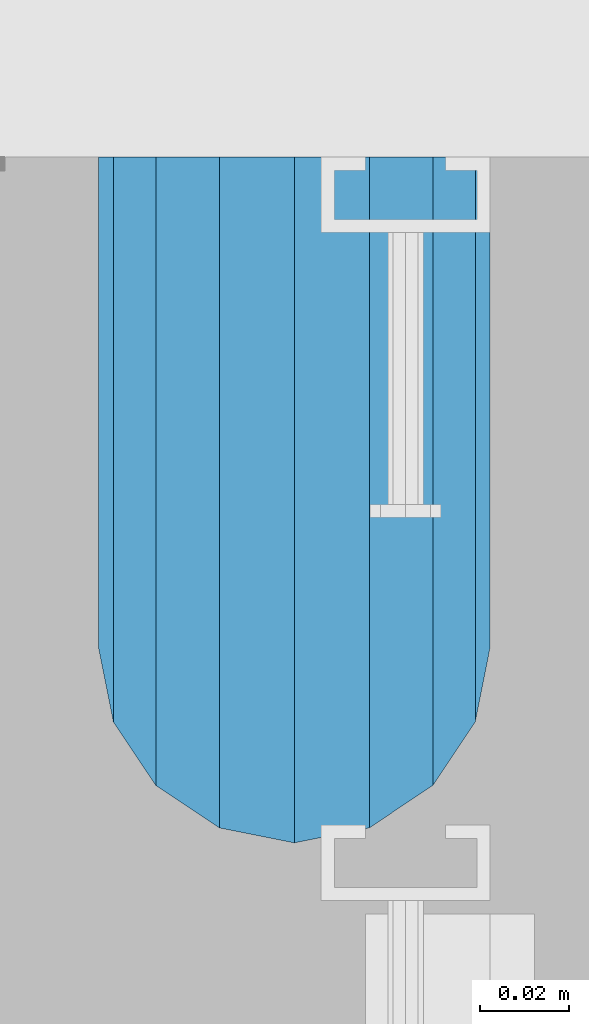
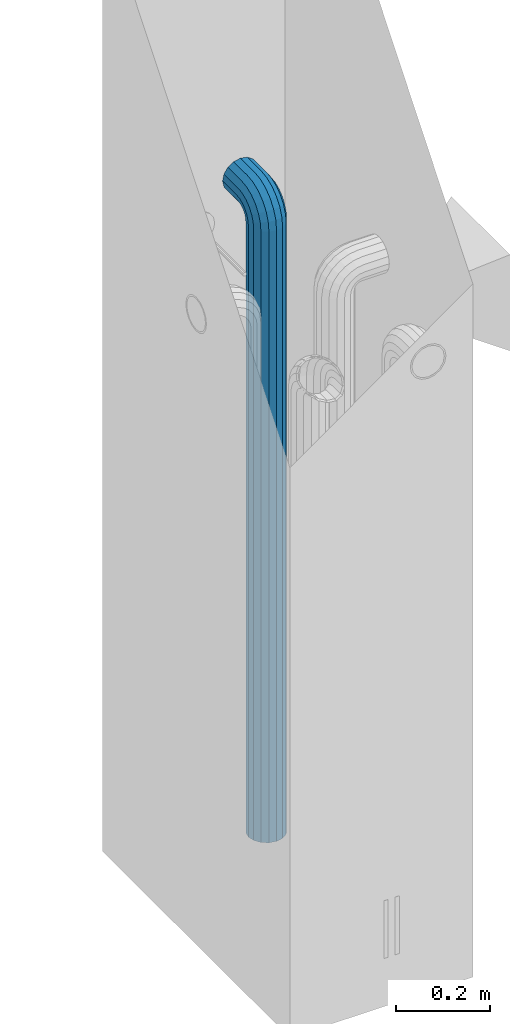
# One storey, part 5 of 41: 1 beam, 2 elements without a shape of their own.
"""IFC2X3 building model written with IfcOpenShell, lengths in millimetres."""

from ifc_helpers import new_model, si_unit, frame, origin_with_axes, place, context, subcontext, project, spatial, faceted_brep, material, type_object, element, aggregate, save


model = new_model("IFC2X3")

# Units and contexts
model_context = context("Model", 3, precision=1e-05, world=origin_with_axes())
body_context = subcontext(model_context, "Body", "Model", "MODEL_VIEW")
ifc_project = project(units=[si_unit("LENGTHUNIT", "METRE", prefix="MILLI"), si_unit("AREAUNIT", "SQUARE_METRE"), si_unit("VOLUMEUNIT", "CUBIC_METRE"), si_unit("MASSUNIT", "GRAM", prefix="KILO"), si_unit("TIMEUNIT", "SECOND"), si_unit("PLANEANGLEUNIT", "RADIAN"), si_unit("SOLIDANGLEUNIT", "STERADIAN"), si_unit("THERMODYNAMICTEMPERATUREUNIT", "DEGREE_CELSIUS"), si_unit("LUMINOUSINTENSITYUNIT", "LUMEN")], contexts=[model_context])

# Site, building, storey
site_placement = place(None, frame((-177556.685383467, -198018.589999756, 1290.0), z_axis=(0.0, 0.0, 1.0), x_axis=(0.788225611989142, -0.615386370180835, 0.0)))
site = spatial("IfcSite", under=ifc_project, at=site_placement, CompositionType="ELEMENT")
building_placement = place(site_placement, origin_with_axes())
building = spatial("IfcBuilding", under=site, at=building_placement, Name="Undefined", CompositionType="ELEMENT")
storey_placement = place(building_placement, origin_with_axes())
storey = spatial("IfcBuildingStorey", under=building, at=storey_placement, Name="Undefined", CompositionType="ELEMENT", Elevation=0.0)

# Assemblies, beam
assembly_1_placement = place(storey_placement, origin_with_axes())
assembly_1 = element("IfcElementAssembly", 1, at=assembly_1_placement, inside=storey, AssemblyPlace="NOTDEFINED", PredefinedType="REINFORCEMENT_UNIT")
assembly_2_placement = place(assembly_1_placement, origin_with_axes())
assembly_2 = element("IfcElementAssembly", 2, at=assembly_2_placement, AssemblyPlace="NOTDEFINED", PredefinedType="RIGID_FRAME")
aggregate(assembly_1, [assembly_2])
ifc_material = material(Name="STEEL/NEG_BETON")
beam_type = type_object("IfcBeamType", PredefinedType="NOTDEFINED")
beam_placement = place(assembly_2_placement, frame((18008.9695688979, 265648.643267305, -1290.0), z_axis=(0.615386370178831, -0.788225611990706, 0.0), x_axis=(0.0, 0.0, 1.0)))
beam = element("IfcBeam", 3, at=beam_placement, type_object=beam_type, material=ifc_material, context=body_context, shape_type="Brep", body=[
    faceted_brep([(0.0, -43.999999753345, 2.88331648334861e-07), (0.0, -40.6506991838105, -16.8380707357428), (1590.0, -40.6506991838105, -16.8380707357428), (1589.99999999999, -43.999999753345, 2.88331648334861e-07), (0.0, -31.1126981254783, -31.1126980838017), (1590.0, -31.1126981254783, -31.1126980838017), (0.0, -16.8380707773322, -40.6506991419883), (1590.0, -16.8380707773322, -40.6506991419883), (0.0, 2.46742274612188e-07, -43.9999997114064), (1590.0, 2.46742274612188e-07, -43.9999997114064), (0.0, 16.8380712707876, -40.6506991418137), (1590.0, 16.8380712707876, -40.6506991418137), (0.0, 31.1126986189047, -31.1126980834524), (1590.0, 31.1126986189047, -31.1126980834524), (0.0, 40.6506996771204, -16.8380707352771), (1590.0, 40.6506996771204, -16.8380707352771), (0.0, 44.0000002465677, 2.88768205791712e-07), (1590.0, 44.0000002465677, 2.88768205791712e-07), (0.0, 40.6506996770622, 16.8380713128427), (1590.0, 40.6506996770622, 16.8380713128427), (0.0, 31.1126986187301, 31.1126986609306), (1590.0, 31.1126986187301, 31.1126986609306), (0.0, 16.8380712705839, 40.6506997191464), (1590.0, 16.8380712705839, 40.6506997191464), (0.0, 2.46509443968534e-07, 44.0000002885354), (1590.0, 2.46509443968534e-07, 44.0000002885354), (0.0, -16.8380707775359, 40.6506997189426), (1590.0, -16.8380707775359, 40.6506997189426), (0.0, -31.1126981256821, 31.1126986605814), (1590.0, -31.1126981256821, 31.1126986605814), (0.0, -40.6506991838978, 16.838071312377), (1590.0, -40.6506991838978, 16.838071312377), (4.47878846898675e-07, -40.0000000634464, 0.0), (4.47878846898675e-07, -36.9551813638827, 15.3073372946019), (1590.0, -36.9551810538396, 15.3073375829845), (1589.99999999999, -39.999999753345, 2.88360752165318e-07), (4.47937054559588e-07, -28.2842713108694, 28.284271247463), (1590.0, -28.2842710008845, 28.2842715359002), (4.4800981413573e-07, -15.3073373580119, 36.9551813004509), (1590.0, -15.3073370480561, 36.9551815889135), (4.48068021796644e-07, -6.34463503956795e-08, 40.0), (1590.0, 2.46538547798991e-07, 40.0000002885645), (4.48140781372786e-07, 15.3073372311774, 36.9551813004509), (1590.0, 15.3073375411332, 36.9551815890882), (4.48213540948927e-07, 28.2842711840058, 28.284271247463), (1590.0, 28.2842714939907, 28.2842715361621), (4.48271748609841e-07, 36.95518123699, 15.3073372946019), (1590.0, 36.9551815469749, 15.3073375833046), (4.48286300525069e-07, 39.9999999365536, 0.0), (1590.0, 40.0000002465677, 2.88768205791712e-07), (4.48271748609841e-07, 36.95518123699, -15.3073372946019), (1590.0, 36.9551815470913, -15.3073370058555), (4.48213540948927e-07, 28.2842711840058, -28.284271247463), (1590.0, 28.2842714941071, -28.2842709587712), (4.48140781372786e-07, 15.3073372311774, -36.9551813004509), (1590.0, 15.3073375413369, -36.9551810117846), (4.48068021796644e-07, -6.34463503956795e-08, -40.0), (1590.0, 2.46742274612188e-07, -39.9999997114064), (4.4800981413573e-07, -15.3073373580119, -36.9551813004509), (1590.0, -15.3073370479106, -36.9551810119592), (4.47937054559588e-07, -28.2842713108694, -28.284271247463), (1590.0, -28.284271000739, -28.2842709590332), (4.47878846898675e-07, -36.9551813638827, -15.3073372946019), (1590.0, -36.9551810537523, -15.3073370062048), (1602.94095225512, -43.9999997526465, -1.70370839745738), (1607.29896571893, -40.6506991831702, 14.560619269585), (1610.99351113838, -31.1126981249254, 28.3488504858688), (1613.46212746447, -16.8380707768374, 37.5618520393036), (1614.32899023963, 2.47237039729953e-07, 40.7970279594592), (1613.46212746447, 16.8380712712533, 37.5618520394491), (1610.99351113838, 31.1126986194577, 28.3488504861598), (1607.29896571893, 40.6506996777607, 14.5606192699925), (1602.94095225512, 44.0000002472952, -1.70370839699171), (1598.5829387913, 40.650699677848, -17.9680360640341), (1594.88839337186, 31.1126986196032, -31.7562672803178), (1592.41977704577, 16.8380712714861, -40.9692688337527), (1591.55291427061, 2.4744076654315e-07, -44.2044447539374), (1592.41977704577, -16.8380707766337, -40.9692688339564), (1594.88839337186, -31.1126981247508, -31.7562672806089), (1598.5829387913, -40.6506991830829, -17.9680360644415), (1613.29371405922, 2.47237039729953e-07, 36.9333246542956), (1612.50565699089, -15.3073370473576, 33.992255635967), (1610.26146033081, -28.284271000186, 25.6167996783042), (1606.90278267677, -36.9551810531411, 13.0820440271636), (1602.94095225512, -39.9999997526465, -1.70370839745738), (1598.97912183347, -36.9551810530538, -16.4894608219911), (1595.62044417943, -28.2842710000114, -29.0242164730153), (1593.37624751934, -15.3073370471539, -37.3996724305616), (1592.58819045102, 2.47411662712693e-07, -40.3407414487447), (1593.37624751934, 15.3073375420063, -37.3996724304452), (1595.62044417943, 28.2842714948347, -29.0242164727533), (1598.97912183347, 36.9551815478189, -16.4894608215836), (1602.94095225512, 40.0000002472952, -1.70370839699171), (1606.90278267677, 36.9551815477316, 13.082044027542), (1610.26146033081, 28.2842714946892, 25.6167996785662), (1612.50565699089, 15.3073375418317, 33.9922556361125), (1630.55634918609, -31.1126981248963, 20.2456576479599), (1635.32534971524, -16.8380707767792, 28.5058088658843), (1623.41903551202, -40.6506991831702, 7.88346773487865), (1614.99999999999, -43.9999997526465, -6.69872952270089), (1606.58096448796, -40.6506991830829, -21.2809267801931), (1599.44365081389, -31.1126981247799, -33.6431166932161), (1594.67465028474, -16.8380707766337, -41.9032679109368), (1592.99999999999, 2.4744076654315e-07, -44.8038472889457), (1594.67465028474, 16.8380712714861, -41.9032679107622), (1599.44365081389, 31.1126986195741, -33.6431166929251), (1606.58096448796, 40.650699677848, -21.2809267798148), (1614.99999999999, 44.0000002472952, -6.69872952226433), (1623.41903551202, 40.6506996777898, 7.88346773531521), (1630.55634918609, 31.1126986194577, 20.24565764828), (1635.32534971524, 16.8380712713115, 28.5058088660007), (1636.99999999999, 2.4726614356041e-07, 31.4063882440387), (1633.47759065022, 15.3073375418608, 25.3053962852573), (1634.99999999999, 2.4726614356041e-07, 27.9422866288805), (1629.14213562372, 28.2842714947183, 17.7961679055006), (1622.65366864729, 36.9551815477607, 6.55781343916897), (1614.99999999999, 40.0000002473244, -6.69872952226433), (1607.34633135269, 36.9551815477898, -19.9552724836976), (1600.85786437626, 28.2842714948347, -31.1936269501166), (1596.52240934976, 15.3073375420354, -38.7028553300188), (1594.99999999999, 2.47411662712693e-07, -41.3397456738458), (1596.52240934976, -15.3073370471539, -38.7028553301352), (1600.85786437626, -28.2842710000696, -31.1936269504367), (1607.34633135269, -36.9551810530538, -19.9552724840469), (1614.99999999999, -39.9999997526465, -6.69872952267178), (1622.65366864729, -36.955181053112, 6.55781343879062), (1629.14213562372, -28.2842710001278, 17.7961679052387), (1633.47759065022, -15.3073370472994, 25.3053962851118), (1647.35533905931, -31.1126981248963, 7.35533934747218), (1654.09972428659, -16.8380707767792, 14.0997245748003), (1637.26165326253, -40.6506991831411, -2.73834644936142), (1625.35533905931, -43.9999997526174, -14.644660652586), (1613.4490248561, -40.650699183112, -26.5509748557815), (1603.35533905931, -31.1126981247508, -36.6446606524696), (1596.61095383203, -16.8380707766046, -43.3890458796814), (1594.24264068711, 2.4744076654315e-07, -45.7573590245447), (1596.61095383203, 16.8380712714861, -43.3890458795358), (1603.35533905931, 31.1126986196032, -36.6446606521786), (1613.4490248561, 40.6506996778771, -26.550974855345), (1625.35533905931, 44.0000002473244, -14.6446606521204), (1637.26165326253, 40.6506996778189, -2.73834644892486), (1647.35533905931, 31.1126986194868, 7.35533934779232), (1654.09972428659, 16.8380712713406, 14.0997245750041), (1656.46803743151, 2.47295247390866e-07, 16.4680377198383), (1651.48659835683, 15.3073375418899, 11.4865986451914), (1653.63961030677, 2.47295247390866e-07, 13.6396105950989), (1645.35533905931, 28.2842714947474, 5.35533934776322), (1636.17926106223, 36.9551815477607, -3.82073864925769), (1625.35533905931, 40.0000002473244, -14.6446606521204), (1614.53141705639, 36.9551815478189, -25.4685826550995), (1605.35533905931, 28.2842714948638, -34.6446606522077), (1599.22407976179, 15.3073375420063, -40.7759199497814), (1597.07106781185, 2.4744076654315e-07, -42.9289318997762), (1599.22407976179, -15.3073370471539, -40.7759199499269), (1605.35533905931, -28.2842710000405, -34.6446606524696), (1614.53141705639, -36.9551810530247, -25.4685826554487), (1625.35533905931, -39.9999997526174, -14.644660652586), (1636.17926106223, -36.9551810530829, -3.82073864963604), (1645.35533905931, -28.2842710001278, 5.35533934750129), (1651.48659835683, -15.3073370472994, 11.486598645075), (1660.24565735981, -31.1126981248381, -9.44365052573266), (1668.50580857761, -16.838070776721, -4.67464999653748), (1647.88346744676, -40.6506991830829, -16.5809641998203), (1633.3012701892, -43.9999997525592, -24.9999997119012), (1618.71907293164, -40.6506991830538, -33.4190352238948), (1606.35688301859, -31.1126981247508, -40.5563488978951), (1598.09673180079, -16.8380707766337, -45.3253494270029), (1595.19615242269, 2.47469870373607e-07, -46.9999997116392), (1598.09673180079, 16.8380712714861, -45.3253494267992), (1606.35688301859, 31.1126986196032, -40.556348897604), (1618.71907293164, 40.6506996778771, -33.4190352235164), (1633.3012701892, 44.0000002473535, -24.9999997114355), (1647.88346744676, 40.650699677848, -16.580964199442), (1660.24565735981, 31.1126986195159, -9.44365052544163), (1668.50580857761, 16.8380712713988, -4.67464999633376), (1671.40638795571, 2.47324351221323e-07, -2.99999971169746), (1665.30539599684, 15.307337541919, -6.52240906140651), (1667.94228634057, 2.47324351221323e-07, -4.99999971172656), (1657.79616761703, 28.2842714948056, -10.8578640878259), (1646.55781315062, 36.9551815477898, -17.3463310641819), (1633.3012701892, 40.0000002473826, -24.9999997114355), (1620.04472722778, 36.955181547848, -32.6536683587765), (1608.80637276137, 28.2842714948638, -39.1421353352489), (1601.29714438156, 15.3073375420063, -43.4775903618138), (1598.66025403783, 2.47469870373607e-07, -44.9999997116392), (1601.29714438156, -15.3073370471539, -43.4775903619302), (1608.80637276137, -28.2842710000114, -39.1421353355108), (1620.04472722778, -36.9551810530247, -32.6536683591548), (1633.3012701892, -39.9999997525883, -24.9999997119012), (1646.55781315062, -36.9551810530538, -17.3463310645602), (1657.79616761703, -28.2842710000987, -10.8578640880878), (1665.30539599684, -15.3073370472412, -6.52240906155203), (1668.34885019768, -31.1126981247799, -29.0064885734755), (1677.56185175105, -16.8380707766628, -26.5378722472815), (1654.56061898146, -40.6506991830538, -32.7010339929548), (1638.29629131443, -43.9999997525592, -37.0590474567725), (1622.0319636474, -40.6506991830538, -41.4170609205903), (1608.24373243118, -31.1126981247508, -45.111606339924), (1599.03073087781, -16.8380707766046, -47.5802226659725), (1595.79555495772, 2.47469870373607e-07, -48.447085441032), (1599.03073087781, 16.8380712715152, -47.5802226657979), (1608.24373243118, 31.1126986196032, -45.1116063396621), (1622.0319636474, 40.6506996779062, -41.4170609201537), (1638.29629131443, 44.0000002474117, -37.059047456336), (1654.56061898146, 40.6506996778771, -32.7010339925182), (1668.34885019768, 31.112698619545, -29.0064885731554), (1677.56185175105, 16.8380712714279, -26.537872247136), (1680.79702767114, 2.47382558882236e-07, -25.6710094720474), (1673.99225534772, 15.3073375420063, -27.494342720689), (1676.93332436598, 2.47382558882236e-07, -26.7062856524717), (1665.61679939011, 28.2842714948056, -29.738539380749), (1653.082043739, 36.9551815478189, -33.0972170347231), (1638.29629131443, 40.0000002473826, -37.059047456336), (1623.51053888986, 36.955181547848, -41.0208778779779), (1610.97578323875, 28.2842714948929, -44.3795555320976), (1602.60032728114, 15.3073375420354, -46.6237521922449), (1599.65925826287, 2.4744076654315e-07, -47.4118092606659), (1602.60032728114, -15.3073370471539, -46.6237521923613), (1610.97578323875, -28.2842710000114, -44.3795555323595), (1623.51053888986, -36.9551810529956, -41.0208778783854), (1638.29629131443, -39.9999997525592, -37.0590474567725), (1653.082043739, -36.9551810529956, -33.0972170350724), (1665.61679939011, -28.2842710000405, -29.73853938104), (1673.99225534772, -15.3073370472121, -27.4943427208927), (1608.88730162777, -31.1126981247216, -49.9999997117848), (1623.16192897591, -40.6506991830247, -49.9999997118721), (1599.34930056949, -16.8380707766046, -49.9999997117557), (1595.99999999998, 2.47469870373607e-07, -49.9999997116684), (1599.34930056949, 16.8380712715152, -49.9999997115519), (1608.88730162777, 31.1126986196323, -49.9999997115228), (1623.16192897591, 40.6506996779353, -49.9999997114355), (1639.99999999997, 44.0000002473826, -49.9999997114646), (1656.83807102403, 40.6506996779353, -49.9999997114355), (1671.11269837217, 31.1126986196323, -49.9999997115228), (1680.65069943045, 16.8380712715152, -49.9999997115519), (1683.99999999996, 2.47469870373607e-07, -49.9999997116684), (1680.65069943045, -16.8380707766046, -49.9999997117557), (1671.11269837217, -31.1126981247216, -49.9999997117848), (1656.83807102403, -40.6506991830247, -49.9999997118721), (1640.0, -43.999999752501, -49.9999997118721), (1676.95518130041, 15.3073375420354, -49.9999997116101), (1679.99999999996, 2.47469870373607e-07, -49.9999997116684), (1668.28427124742, 28.2842714948929, -49.9999997114937), (1655.30733729457, 36.9551815478771, -49.9999997114937), (1639.99999999997, 40.0000002474117, -49.9999997114937), (1624.69266270537, 36.9551815478771, -49.9999997114937), (1611.71572875252, 28.2842714948929, -49.9999997114937), (1603.04481869953, 15.3073375420354, -49.9999997116101), (1599.99999999998, 2.47469870373607e-07, -49.9999997116684), (1603.04481869953, -15.3073370471539, -49.9999997117266), (1611.71572875252, -28.2842710000114, -49.9999997118139), (1624.69266270537, -36.9551810529665, -49.9999997118139), (1640.0, -39.9999997525301, -49.999999711843), (1655.30733729457, -36.9551810529665, -49.999999711843), (1668.28427124742, -28.2842710000114, -49.9999997118139), (1676.95518130041, -15.3073370471247, -49.9999997117266), (1623.16192897594, -40.6506991828792, -109.999999711843), (1640.0, -43.9999997523555, -109.999999711843), (1608.88730162779, -31.1126981245761, -109.999999711785), (1599.3493005695, -16.8380707764591, -109.999999711727), (1596.0, 2.4761538952589e-07, -109.999999711639), (1599.3493005695, 16.8380712716607, -109.999999711552), (1608.88730162779, 31.1126986197778, -109.999999711494), (1623.16192897594, 40.6506996780809, -109.999999711406), (1640.0, 44.0000002475572, -109.999999711436), (1656.83807102406, 40.6506996780809, -109.999999711406), (1671.11269837221, 31.1126986197778, -109.999999711494), (1680.6506994305, 16.8380712716607, -109.999999711552), (1684.0, 2.4761538952589e-07, -109.999999711639), (1680.6506994305, -16.8380707764591, -109.999999711727), (1671.11269837221, -31.1126981245761, -109.999999711785), (1656.83807102406, -40.6506991828792, -109.999999711843), (1655.3073372946, -36.9551810527919, -109.999999711785), (1640.0, -39.9999997523846, -109.999999711843), (1668.28427124746, -28.2842709998658, -109.999999711785), (1676.95518130045, -15.3073370469792, -109.999999711727), (1680.0, 2.4761538952589e-07, -109.999999711639), (1676.95518130045, 15.3073375421809, -109.999999711581), (1668.28427124746, 28.2842714950675, -109.999999711465), (1655.3073372946, 36.9551815479936, -109.999999711465), (1640.0, 40.0000002475572, -109.999999711465), (1624.6926627054, 36.9551815479936, -109.999999711465), (1611.71572875254, 28.2842714950675, -109.999999711465), (1603.04481869955, 15.3073375421809, -109.999999711581), (1600.0, 2.4761538952589e-07, -109.999999711639), (1603.04481869955, -15.3073370469792, -109.999999711727), (1611.71572875254, -28.2842709998658, -109.999999711785), (1624.6926627054, -36.9551810527919, -109.999999711785)], [[[0, 1, 2, 3]], [[1, 4, 5, 2]], [[4, 6, 7, 5]], [[6, 8, 9, 7]], [[8, 10, 11, 9]], [[10, 12, 13, 11]], [[12, 14, 15, 13]], [[14, 16, 17, 15]], [[16, 18, 19, 17]], [[18, 20, 21, 19]], [[20, 22, 23, 21]], [[22, 24, 25, 23]], [[24, 26, 27, 25]], [[26, 28, 29, 27]], [[28, 30, 31, 29]], [[30, 0, 3, 31]], [[32, 33, 34, 35]], [[33, 36, 37, 34]], [[36, 38, 39, 37]], [[38, 40, 41, 39]], [[40, 42, 43, 41]], [[42, 44, 45, 43]], [[44, 46, 47, 45]], [[46, 48, 49, 47]], [[48, 50, 51, 49]], [[50, 52, 53, 51]], [[52, 54, 55, 53]], [[54, 56, 57, 55]], [[56, 58, 59, 57]], [[58, 60, 61, 59]], [[60, 62, 63, 61]], [[62, 32, 35, 63]], [[30, 28, 26, 24, 22, 20, 18, 16, 14, 12, 10, 8, 6, 4, 1, 0], [62, 60, 58, 56, 54, 52, 50, 48, 46, 44, 42, 40, 38, 36, 33, 32]], [[31, 3, 64, 65]], [[29, 31, 65, 66]], [[27, 29, 66, 67]], [[25, 27, 67, 68]], [[23, 25, 68, 69]], [[21, 23, 69, 70]], [[19, 21, 70, 71]], [[17, 19, 71, 72]], [[15, 17, 72, 73]], [[13, 15, 73, 74]], [[11, 13, 74, 75]], [[9, 11, 75, 76]], [[7, 9, 76, 77]], [[5, 7, 77, 78]], [[2, 5, 78, 79]], [[3, 2, 79, 64]], [[39, 41, 80, 81]], [[37, 39, 81, 82]], [[34, 37, 82, 83]], [[35, 34, 83, 84]], [[63, 35, 84, 85]], [[61, 63, 85, 86]], [[59, 61, 86, 87]], [[57, 59, 87, 88]], [[55, 57, 88, 89]], [[53, 55, 89, 90]], [[51, 53, 90, 91]], [[49, 51, 91, 92]], [[47, 49, 92, 93]], [[45, 47, 93, 94]], [[43, 45, 94, 95]], [[41, 43, 95, 80]], [[66, 96, 97, 67]], [[65, 98, 96, 66]], [[64, 99, 98, 65]], [[79, 100, 99, 64]], [[78, 101, 100, 79]], [[77, 102, 101, 78]], [[76, 103, 102, 77]], [[75, 104, 103, 76]], [[74, 105, 104, 75]], [[73, 106, 105, 74]], [[72, 107, 106, 73]], [[71, 108, 107, 72]], [[70, 109, 108, 71]], [[69, 110, 109, 70]], [[68, 111, 110, 69]], [[67, 97, 111, 68]], [[95, 112, 113, 80]], [[94, 114, 112, 95]], [[93, 115, 114, 94]], [[92, 116, 115, 93]], [[91, 117, 116, 92]], [[90, 118, 117, 91]], [[89, 119, 118, 90]], [[88, 120, 119, 89]], [[87, 121, 120, 88]], [[86, 122, 121, 87]], [[85, 123, 122, 86]], [[84, 124, 123, 85]], [[83, 125, 124, 84]], [[82, 126, 125, 83]], [[81, 127, 126, 82]], [[80, 113, 127, 81]], [[96, 128, 129, 97]], [[98, 130, 128, 96]], [[99, 131, 130, 98]], [[100, 132, 131, 99]], [[101, 133, 132, 100]], [[102, 134, 133, 101]], [[103, 135, 134, 102]], [[104, 136, 135, 103]], [[105, 137, 136, 104]], [[106, 138, 137, 105]], [[107, 139, 138, 106]], [[108, 140, 139, 107]], [[109, 141, 140, 108]], [[110, 142, 141, 109]], [[111, 143, 142, 110]], [[97, 129, 143, 111]], [[112, 144, 145, 113]], [[114, 146, 144, 112]], [[115, 147, 146, 114]], [[116, 148, 147, 115]], [[117, 149, 148, 116]], [[118, 150, 149, 117]], [[119, 151, 150, 118]], [[120, 152, 151, 119]], [[121, 153, 152, 120]], [[122, 154, 153, 121]], [[123, 155, 154, 122]], [[124, 156, 155, 123]], [[125, 157, 156, 124]], [[126, 158, 157, 125]], [[127, 159, 158, 126]], [[113, 145, 159, 127]], [[128, 160, 161, 129]], [[130, 162, 160, 128]], [[131, 163, 162, 130]], [[132, 164, 163, 131]], [[133, 165, 164, 132]], [[134, 166, 165, 133]], [[135, 167, 166, 134]], [[136, 168, 167, 135]], [[137, 169, 168, 136]], [[138, 170, 169, 137]], [[139, 171, 170, 138]], [[140, 172, 171, 139]], [[141, 173, 172, 140]], [[142, 174, 173, 141]], [[143, 175, 174, 142]], [[129, 161, 175, 143]], [[144, 176, 177, 145]], [[146, 178, 176, 144]], [[147, 179, 178, 146]], [[148, 180, 179, 147]], [[149, 181, 180, 148]], [[150, 182, 181, 149]], [[151, 183, 182, 150]], [[152, 184, 183, 151]], [[153, 185, 184, 152]], [[154, 186, 185, 153]], [[155, 187, 186, 154]], [[156, 188, 187, 155]], [[157, 189, 188, 156]], [[158, 190, 189, 157]], [[159, 191, 190, 158]], [[145, 177, 191, 159]], [[160, 192, 193, 161]], [[162, 194, 192, 160]], [[163, 195, 194, 162]], [[164, 196, 195, 163]], [[165, 197, 196, 164]], [[166, 198, 197, 165]], [[167, 199, 198, 166]], [[168, 200, 199, 167]], [[169, 201, 200, 168]], [[170, 202, 201, 169]], [[171, 203, 202, 170]], [[172, 204, 203, 171]], [[173, 205, 204, 172]], [[174, 206, 205, 173]], [[175, 207, 206, 174]], [[161, 193, 207, 175]], [[176, 208, 209, 177]], [[178, 210, 208, 176]], [[179, 211, 210, 178]], [[180, 212, 211, 179]], [[181, 213, 212, 180]], [[182, 214, 213, 181]], [[183, 215, 214, 182]], [[184, 216, 215, 183]], [[185, 217, 216, 184]], [[186, 218, 217, 185]], [[187, 219, 218, 186]], [[188, 220, 219, 187]], [[189, 221, 220, 188]], [[190, 222, 221, 189]], [[191, 223, 222, 190]], [[177, 209, 223, 191]], [[197, 224, 225, 196]], [[198, 226, 224, 197]], [[199, 227, 226, 198]], [[200, 228, 227, 199]], [[201, 229, 228, 200]], [[202, 230, 229, 201]], [[203, 231, 230, 202]], [[204, 232, 231, 203]], [[205, 233, 232, 204]], [[206, 234, 233, 205]], [[207, 235, 234, 206]], [[193, 236, 235, 207]], [[192, 237, 236, 193]], [[194, 238, 237, 192]], [[195, 239, 238, 194]], [[196, 225, 239, 195]], [[208, 240, 241, 209]], [[210, 242, 240, 208]], [[211, 243, 242, 210]], [[212, 244, 243, 211]], [[213, 245, 244, 212]], [[214, 246, 245, 213]], [[215, 247, 246, 214]], [[216, 248, 247, 215]], [[217, 249, 248, 216]], [[218, 250, 249, 217]], [[219, 251, 250, 218]], [[220, 252, 251, 219]], [[221, 253, 252, 220]], [[222, 254, 253, 221]], [[223, 255, 254, 222]], [[209, 241, 255, 223]], [[239, 225, 256, 257]], [[225, 224, 258, 256]], [[224, 226, 259, 258]], [[226, 227, 260, 259]], [[227, 228, 261, 260]], [[228, 229, 262, 261]], [[229, 230, 263, 262]], [[230, 231, 264, 263]], [[231, 232, 265, 264]], [[232, 233, 266, 265]], [[233, 234, 267, 266]], [[234, 235, 268, 267]], [[235, 236, 269, 268]], [[236, 237, 270, 269]], [[237, 238, 271, 270]], [[238, 239, 257, 271]], [[252, 253, 272, 273]], [[253, 254, 274, 272]], [[254, 255, 275, 274]], [[255, 241, 276, 275]], [[241, 240, 277, 276]], [[240, 242, 278, 277]], [[242, 243, 279, 278]], [[243, 244, 280, 279]], [[244, 245, 281, 280]], [[245, 246, 282, 281]], [[246, 247, 283, 282]], [[247, 248, 284, 283]], [[248, 249, 285, 284]], [[249, 250, 286, 285]], [[250, 251, 287, 286]], [[251, 252, 273, 287]], [[258, 259, 260, 261, 262, 263, 264, 265, 266, 267, 268, 269, 270, 271, 257, 256], [274, 275, 276, 277, 278, 279, 280, 281, 282, 283, 284, 285, 286, 287, 273, 272]]]),
])
aggregate(assembly_2, [beam])

save(model, "model.ifc")
